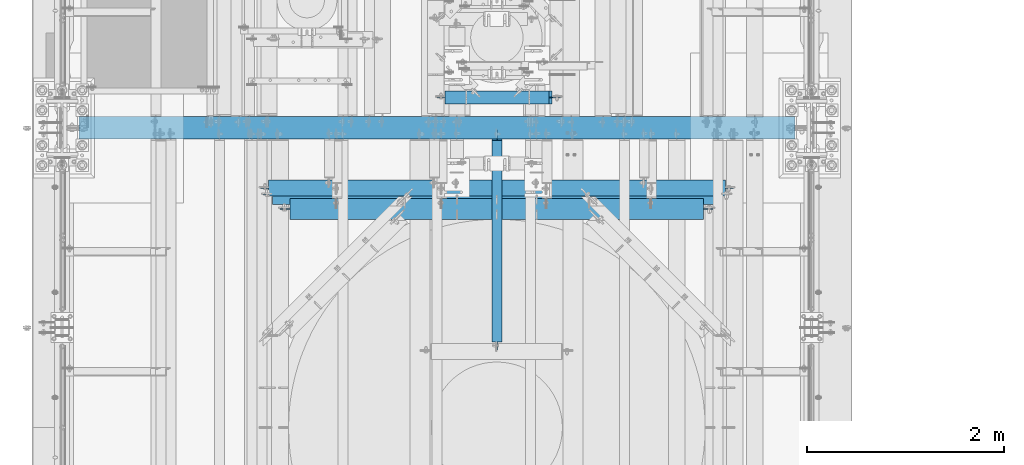
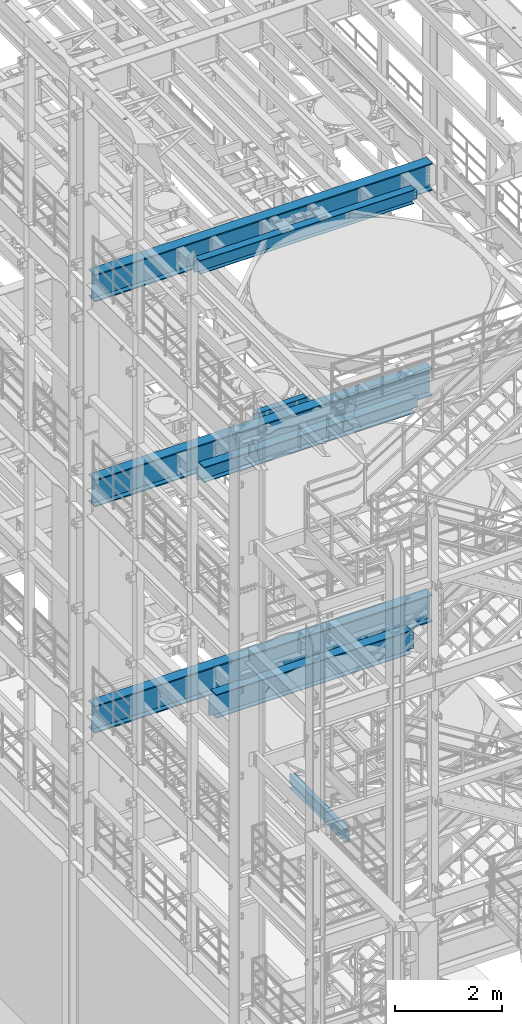
# One storey, part 1014 of 1876: 8 beams, 8 elements without a shape of their own.
"""IFC2X3 building model written with IfcOpenShell, lengths in millimetres."""

from ifc_helpers import new_model, si_unit, frame, origin_with_axes, place, context, subcontext, project, spatial, faceted_brep, material, type_object, element, aggregate, save


model = new_model("IFC2X3")

# Units and contexts
model_context = context("Model", 3, precision=1e-05, world=origin_with_axes())
body_context = subcontext(model_context, "Body", "Model", "MODEL_VIEW")
ifc_project = project(units=[si_unit("LENGTHUNIT", "METRE", prefix="MILLI"), si_unit("AREAUNIT", "SQUARE_METRE"), si_unit("VOLUMEUNIT", "CUBIC_METRE"), si_unit("MASSUNIT", "GRAM", prefix="KILO"), si_unit("TIMEUNIT", "SECOND"), si_unit("PLANEANGLEUNIT", "RADIAN"), si_unit("SOLIDANGLEUNIT", "STERADIAN"), si_unit("THERMODYNAMICTEMPERATUREUNIT", "DEGREE_CELSIUS"), si_unit("LUMINOUSINTENSITYUNIT", "LUMEN")], contexts=[model_context])

# Site, building, storey
site_placement = place(None, origin_with_axes())
site = spatial("IfcSite", under=ifc_project, at=site_placement, CompositionType="ELEMENT")
building_placement = place(site_placement, origin_with_axes())
building = spatial("IfcBuilding", under=site, at=building_placement, Name="Undefined", CompositionType="ELEMENT")
storey_placement = place(building_placement, origin_with_axes())
storey = spatial("IfcBuildingStorey", under=building, at=storey_placement, Name="Undefined", CompositionType="ELEMENT", Elevation=0.0)

# Assembly, beam
assembly_1_placement = place(storey_placement, origin_with_axes())
assembly_1 = element("IfcElementAssembly", 1, at=assembly_1_placement, inside=storey, Name="BEAM", AssemblyPlace="NOTDEFINED", PredefinedType="RIGID_FRAME")
ifc_material = material(Name="STEEL/A992")
beam_type_1 = type_object("IfcBeamType", Name="W12X16", PredefinedType="NOTDEFINED")
beam_1_placement = place(assembly_1_placement, frame((4422.775, -717.55, 4978.4), z_axis=(0.0, 0.0, 1.0), x_axis=(0.0, 1.0, 0.0)))
beam_1 = element("IfcBeam", 2, at=beam_1_placement, type_object=beam_type_1, material=ifc_material, Name="BEAM", ObjectType="W12X16", context=body_context, shape_type="Brep", body=[
    faceted_brep([(-15.875, -3.17500000000018, -126.999999999999), (-15.875, 3.17500000000018, -126.999999999999), (66.6750000000002, 3.17499999999995, -127.0), (66.6750000000002, -3.17499999999995, -127.0), (71.5350797087794, 3.17499999999995, -127.966729922588), (71.5350797087794, -3.17499999999995, -127.966729922588), (75.6552561769331, 3.17499999999995, -130.719743823067), (75.6552561769331, -3.17499999999995, -130.719743823067), (78.4082700774111, 3.17499999999995, -134.839920291221), (78.4082700774111, -3.17499999999995, -134.839920291221), (79.3749999999991, -3.17499999999995, -139.699999809266), (79.3749999999991, 3.17499999999995, -139.699999809266), (79.3749999999991, 3.17499999999995, -146.05), (79.3749999999991, 50.8, -146.05), (79.3749999999991, 50.8, -152.4), (79.3749999999991, -50.8, -152.4), (79.3749999999991, -50.8, -146.05), (79.3749999999991, -3.17499999999995, -146.05), (2113.75625, 50.8000000000002, 146.05), (2113.75625, 3.17500000000018, 146.05), (63.5000000000009, 3.17499999999927, 146.049999999999), (63.4999999247211, 50.8000000000002, 146.049999999999), (50.800000115456, -3.17500000000018, 127.000000000004), (50.800000115456, 3.17500000000018, 127.000000000004), (-15.875, 3.17500000000018, 127.000000000001), (-15.875, -3.17500000000018, 127.000000000001), (55.6600796335015, -3.17500000000018, 127.966729922591), (55.6600796335015, 3.17500000000018, 127.966729922591), (59.7802561016551, -3.17500000000018, 130.719743823069), (59.7802561016551, 3.17500000000018, 130.719743823069), (62.5332700021336, -3.17500000000018, 134.839920291222), (62.5332700021336, 3.17500000000018, 134.839920291222), (63.4999999247211, -3.17500000000018, 139.699999809269), (63.4999999247211, 3.17500000000018, 139.699999809269), (2113.75625, -50.8000000000002, 152.4), (2113.75625, 50.8000000000002, 152.4), (63.4999999247211, 50.8000000000002, 152.400000000001), (63.4999999247211, -50.8000000000002, 152.400000000001), (2113.75625, -50.8000000000002, 146.05), (63.4999999247211, -50.8000000000002, 146.049999999999), (2113.75625, -3.17500000000018, 146.05), (63.5000000000009, -3.17499999999927, 146.049999999999), (2113.75625, -3.17500000000018, 126.999999809264), (2113.75625, 3.17500000000018, 126.999999809264), (2114.72297992259, -3.17500000000018, 122.139920291219), (2114.72297992259, 3.17500000000018, 122.139920291219), (2117.47599382307, -3.17500000000018, 118.019743823065), (2117.47599382307, 3.17500000000018, 118.019743823065), (2121.59617029122, -3.17500000000018, 115.266729922587), (2121.59617029122, 3.17500000000018, 115.266729922587), (2126.45624980927, -3.17500000000018, 114.299999999999), (2126.45624980927, 3.17500000000018, 114.299999999999), (2221.70625, -3.17500000000018, 114.299999999999), (2221.70625, 3.17500000000018, 114.299999999999), (2221.70625, -3.17500000000018, -127.000000000001), (2221.70625, 3.17500000000018, -127.000000000001), (2139.15624980927, -3.17500000000018, -127.000000000001), (2139.15624980927, 3.17500000000018, -127.000000000001), (2134.29617029122, -3.17500000000018, -127.966729922588), (2134.29617029122, 3.17500000000018, -127.966729922588), (2130.17599382307, -3.17500000000018, -130.719743823067), (2130.17599382307, 3.17500000000018, -130.719743823067), (2127.42297992259, -3.17500000000018, -134.839920291221), (2127.42297992259, 3.17500000000018, -134.839920291221), (2126.45625, -3.17500000000018, -139.699999809266), (2126.45625, 3.17500000000018, -139.699999809266), (2126.45625, -3.17500000000018, -146.05), (2126.45625, -50.8000000000002, -146.05), (2126.45625, -50.8000000000002, -152.4), (2126.45625, 50.8000000000002, -152.4), (2126.45625, 50.8000000000002, -146.05), (2126.45625, 3.17500000000018, -146.05)], [[[0, 1, 2, 3]], [[3, 2, 4, 5]], [[5, 4, 6, 7]], [[7, 6, 8, 9]], [[10, 11, 12, 13, 14, 15, 16, 17]], [[9, 8, 11, 10]], [[18, 19, 20, 21]], [[22, 23, 24, 25]], [[26, 27, 23, 22]], [[28, 29, 27, 26]], [[30, 31, 29, 28]], [[32, 33, 31, 30]], [[34, 35, 36, 37]], [[38, 34, 37, 39]], [[40, 38, 39, 41]], [[37, 36, 21, 20, 33, 32, 41, 39]], [[35, 18, 21, 36]], [[34, 38, 40, 42, 43, 19, 18, 35]], [[44, 45, 43, 42]], [[46, 47, 45, 44]], [[48, 49, 47, 46]], [[50, 51, 49, 48]], [[52, 53, 51, 50]], [[53, 52, 54, 55]], [[54, 56, 57, 55]], [[58, 59, 57, 56]], [[60, 61, 59, 58]], [[62, 63, 61, 60]], [[64, 65, 63, 62]], [[66, 67, 68, 69, 70, 71, 65, 64]], [[67, 66, 17, 16]], [[68, 67, 16, 15]], [[69, 68, 15, 14]], [[70, 69, 14, 13]], [[71, 70, 13, 12]], [[6, 4, 2, 1, 24, 23, 27, 29, 31, 33, 20, 19, 43, 45, 47, 49, 51, 53, 55, 57, 59, 61, 63, 65, 71, 12, 11, 8]], [[25, 24, 1, 0]], [[66, 64, 62, 60, 58, 56, 54, 52, 50, 48, 46, 44, 42, 40, 41, 32, 30, 28, 26, 22, 25, 0, 3, 5, 7, 9, 10, 17]]]),
])
aggregate(assembly_1, [beam_1])

assembly_2_placement = place(storey_placement, origin_with_axes())
assembly_2 = element("IfcElementAssembly", 3, at=assembly_2_placement, inside=storey, Name="BEAM", AssemblyPlace="NOTDEFINED", PredefinedType="RIGID_FRAME")
beam_type_2 = type_object("IfcBeamType", Name="W8X18", PredefinedType="NOTDEFINED")
beam_2_placement = place(assembly_2_placement, frame((3892.55, 1831.975, 13206.4125), z_axis=(0.0, 0.0, 1.0), x_axis=(1.0, 0.0, 0.0)))
beam_2 = element("IfcBeam", 4, at=beam_2_placement, type_object=beam_type_2, material=ifc_material, Name="BEAM", ObjectType="W8X18", context=body_context, shape_type="Brep", body=[
    faceted_brep([(1086.64375, -3.17500000000018, -95.25), (1086.64375, -66.6750000000002, -95.25), (1086.64375, -66.6750000000002, -103.1875), (1086.64375, 66.6750000000002, -103.1875), (1086.64375, 66.6750000000002, -95.25), (1086.64375, 3.17500000000018, -95.25), (1086.64375, 3.17500000000018, -90.4874998092673), (1086.64375, -3.17500000000018, -90.4874998092673), (1087.61047992259, 3.17500000000018, -85.6274202912209), (1087.61047992259, -3.17500000000018, -85.6274202912209), (1090.36349382307, 3.17500000000018, -81.5072438230673), (1090.36349382307, -3.17500000000018, -81.5072438230673), (1094.48367029122, 3.17500000000018, -78.7542299225897), (1094.48367029122, -3.17500000000018, -78.7542299225897), (1099.34374980927, 3.17500000000018, -77.7875000000022), (1099.34374980927, -3.17500000000018, -77.7875000000022), (1175.54375, -3.17500000000018, -77.7875000000022), (1175.54375, 3.17500000000018, -77.7875000000022), (4.54747350886464e-13, 3.17500000000018, 95.25), (4.54747350886464e-13, 66.6750000000002, 95.25), (1054.89375, 66.6750000000002, 95.25), (1054.89375, 3.17500000000018, 95.25), (9.52500000000055, -3.17500000000018, -90.4874998092655), (9.52500000000055, 3.17500000000018, -90.4874998092655), (9.52500000000055, 3.17500000000018, -95.25), (9.52500000000055, 66.6750000000002, -95.25), (9.52500000000055, 66.6750000000002, -103.1875), (9.52500000000055, -66.6750000000002, -103.1875), (9.52500000000055, -66.6750000000002, -95.25), (9.52500000000055, -3.17500000000018, -95.25), (8.55827007741254, -3.17500000000018, -85.6274202912191), (8.55827007741254, 3.17500000000018, -85.6274202912191), (5.80525617693456, -3.17500000000018, -81.5072438230654), (5.80525617693456, 3.17500000000018, -81.5072438230654), (1.6850797087809, -3.17500000000018, -78.7542299225879), (1.6850797087809, 3.17500000000018, -78.7542299225879), (-3.17499980926459, -3.17500000000018, -77.7875000000004), (-3.17499980926459, 3.17500000000018, -77.7875000000004), (-79.3750000000005, -3.17500000000018, -77.7875000000004), (-79.3750000000005, 3.17500000000018, -77.7875000000004), (-79.3750000000005, -3.17500000000018, 77.7875000000004), (-79.3750000000005, 3.17500000000018, 77.7875000000004), (-12.6999998092647, -3.17500000000018, 77.7875000000004), (-12.6999998092647, 3.17500000000018, 77.7875000000004), (-7.83992029121919, -3.17500000000018, 78.7542299225879), (-7.83992029121919, 3.17500000000018, 78.7542299225879), (-3.71974382306553, -3.17500000000018, 81.5072438230654), (-3.71974382306553, 3.17500000000018, 81.5072438230654), (-0.966729922587547, -3.17500000000018, 85.6274202912191), (-0.966729922587547, 3.17500000000018, 85.6274202912191), (4.54747350886464e-13, -3.17500000000018, 90.4874998092655), (4.54747350886464e-13, 3.17500000000018, 90.4874998092655), (4.54747350886464e-13, -66.6750000000002, 103.1875), (4.54747350886464e-13, 66.6750000000002, 103.1875), (4.54747350886464e-13, -3.17500000000018, 95.25), (4.54747350886464e-13, -66.6750000000002, 95.25), (1054.89375, -3.17500000000018, 95.25), (1054.89375, -66.6750000000002, 95.25), (1054.89375, -66.6750000000002, 103.1875), (1054.89375, 66.6750000000002, 103.1875), (1054.89375, -3.17500000000018, 90.4874998092637), (1054.89375, 3.17500000000018, 90.4874998092637), (1055.86047992259, -3.17500000000018, 85.6274202912173), (1055.86047992259, 3.17500000000018, 85.6274202912173), (1058.61349382307, -3.17500000000018, 81.5072438230636), (1058.61349382307, 3.17500000000018, 81.5072438230636), (1062.73367029122, -3.17500000000018, 78.7542299225861), (1062.73367029122, 3.17500000000018, 78.7542299225861), (1067.59374980927, -3.17500000000018, 77.7874999999985), (1067.59374980927, 3.17500000000018, 77.7874999999985), (1175.54375, -3.17500000000018, 77.7874999999985), (1175.54375, 3.17500000000018, 77.7874999999985)], [[[0, 1, 2, 3, 4, 5, 6, 7]], [[7, 6, 8, 9]], [[9, 8, 10, 11]], [[11, 10, 12, 13]], [[13, 12, 14, 15]], [[16, 15, 14, 17]], [[18, 19, 20, 21]], [[22, 23, 24, 25, 26, 27, 28, 29]], [[30, 31, 23, 22]], [[32, 33, 31, 30]], [[34, 35, 33, 32]], [[36, 37, 35, 34]], [[38, 39, 37, 36]], [[40, 41, 39, 38]], [[42, 43, 41, 40]], [[44, 45, 43, 42]], [[46, 47, 45, 44]], [[48, 49, 47, 46]], [[50, 51, 49, 48]], [[52, 53, 19, 18, 51, 50, 54, 55]], [[55, 54, 56, 57]], [[52, 55, 57, 58]], [[53, 52, 58, 59]], [[19, 53, 59, 20]], [[58, 57, 56, 60, 61, 21, 20, 59]], [[62, 63, 61, 60]], [[64, 65, 63, 62]], [[66, 67, 65, 64]], [[68, 69, 67, 66]], [[70, 71, 69, 68]], [[71, 70, 16, 17]], [[33, 35, 37, 39, 41, 43, 45, 47, 49, 51, 18, 21, 61, 63, 65, 67, 69, 71, 17, 14, 12, 10, 8, 6, 5, 24, 23, 31]], [[5, 4, 25, 24]], [[4, 3, 26, 25]], [[3, 2, 27, 26]], [[2, 1, 28, 27]], [[1, 0, 29, 28]], [[0, 7, 9, 11, 13, 15, 16, 70, 68, 66, 64, 62, 60, 56, 54, 50, 48, 46, 44, 42, 40, 38, 36, 34, 32, 30, 22, 29]]]),
])
aggregate(assembly_2, [beam_2])

assembly_3_placement = place(storey_placement, origin_with_axes())
assembly_3 = element("IfcElementAssembly", 5, at=assembly_3_placement, inside=storey, Name="BEAM", AssemblyPlace="NOTDEFINED", PredefinedType="RIGID_FRAME")
beam_type_3 = type_object("IfcBeamType", Name="W12X30", PredefinedType="NOTDEFINED")
beam_3_placement = place(assembly_3_placement, frame((1930.40018598705, 911.224999999455, 17826.0375), z_axis=(0.0, 0.0, 1.0), x_axis=(1.0, 0.0, 0.0)))
beam_3 = element("IfcBeam", 6, at=beam_3_placement, type_object=beam_type_3, material=ifc_material, Name="BEAM", ObjectType="W12X30", context=body_context, shape_type="Brep", body=[
    faceted_brep([(4797.4246272902, -3.17499999999995, -146.049999999999), (4797.4246272902, -82.55, -146.049999999999), (4797.4246272902, -82.55, -157.162499999999), (4797.4246272902, 82.55, -157.162499999999), (4797.4246272902, 82.55, -146.049999999999), (4797.4246272902, 3.17499999999995, -146.049999999999), (4797.4246272902, 3.17499999999995, -138.112499809271), (4797.4246272902, -3.17499999999995, -138.112499809271), (4798.39135721279, 3.17499999999995, -133.252420291225), (4798.39135721279, -3.17499999999995, -133.252420291225), (4801.14437111326, 3.17499999999995, -129.132243823071), (4801.14437111326, -3.17499999999995, -129.132243823071), (4805.26454758142, 3.17499999999995, -126.379229922593), (4805.26454758142, -3.17499999999995, -126.379229922593), (4810.12462709946, 3.17499999999995, -125.412500000006), (4810.12462709946, -3.17499999999995, -125.412500000006), (4892.6746272902, -3.17499999999995, -125.412500000006), (4892.6746272902, 3.17499999999995, -125.412500000006), (165.099700464235, 3.17499999999995, 146.049999999999), (165.099700464235, 82.55, 146.049999999999), (4813.2996272902, 82.55, 146.049999999999), (4813.2996272902, 3.17499999999995, 146.049999999999), (180.974700464235, -3.17500000000007, -138.112499809271), (180.974700464235, 3.17499999999995, -138.112499809271), (180.974700464235, 3.17499999999995, -146.049999999999), (180.974700464235, 82.55, -146.049999999999), (180.974700464235, 82.55, -157.162499999999), (180.974700464235, -82.55, -157.162499999999), (180.974700464235, -82.55, -146.049999999999), (180.974700464235, -3.17499999999995, -146.049999999999), (180.007970541647, -3.17500000000007, -133.252420291225), (180.007970541647, 3.17499999999995, -133.252420291225), (177.254956641169, -3.17500000000007, -129.132243823071), (177.254956641169, 3.17499999999995, -129.132243823071), (173.134780173015, -3.17500000000007, -126.379229922593), (173.134780173015, 3.17499999999995, -126.379229922593), (168.27470065497, -3.17500000000007, -125.412500000006), (168.27470065497, 3.17499999999995, -125.412500000006), (85.7247004642345, -3.17499999999995, -125.412500000006), (85.7247004642345, 3.17499999999995, -125.412500000006), (85.7247004642345, -3.17499999999995, 131.762499999997), (85.7247004642345, 3.17499999999995, 131.762499999997), (152.39970065497, -3.17499999999995, 131.762499999997), (152.39970065497, 3.17499999999995, 131.762499999997), (157.259780173015, -3.17499999999995, 132.729229922585), (157.259780173015, 3.17499999999995, 132.729229922585), (161.379956641169, -3.17499999999995, 135.482243823062), (161.379956641169, 3.17499999999995, 135.482243823062), (164.132970541647, -3.17499999999995, 139.602420291216), (164.132970541647, 3.17499999999995, 139.602420291216), (165.099700464235, -3.17499999999995, 144.462499809262), (165.099700464235, 3.17499999999995, 144.462499809262), (165.099700464235, -82.55, 157.162499999999), (165.099700464235, 82.55, 157.162499999999), (165.099700464235, -3.17499999999995, 146.049999999999), (165.099700464235, -82.55, 146.049999999999), (4813.2996272902, -3.17499999999995, 146.049999999999), (4813.2996272902, -82.55, 146.049999999999), (4813.2996272902, -82.55, 157.162499999999), (4813.2996272902, 82.55, 157.162499999999), (4813.2996272902, -3.17499999999995, 144.462499809262), (4813.2996272902, 3.17500000000007, 144.462499809262), (4814.26635721279, -3.17499999999995, 139.602420291216), (4814.26635721279, 3.17500000000007, 139.602420291216), (4817.01937111326, -3.17499999999995, 135.482243823062), (4817.01937111326, 3.17500000000007, 135.482243823062), (4821.13954758142, -3.17499999999995, 132.729229922585), (4821.13954758142, 3.17500000000007, 132.729229922585), (4825.99962709946, -3.17499999999995, 131.762499999997), (4825.99962709946, 3.17500000000007, 131.762499999997), (4892.6746272902, -3.17499999999995, 131.762499999997), (4892.6746272902, 3.17499999999995, 131.762499999997)], [[[0, 1, 2, 3, 4, 5, 6, 7]], [[7, 6, 8, 9]], [[9, 8, 10, 11]], [[11, 10, 12, 13]], [[13, 12, 14, 15]], [[16, 15, 14, 17]], [[18, 19, 20, 21]], [[22, 23, 24, 25, 26, 27, 28, 29]], [[30, 31, 23, 22]], [[32, 33, 31, 30]], [[34, 35, 33, 32]], [[36, 37, 35, 34]], [[38, 39, 37, 36]], [[40, 41, 39, 38]], [[42, 43, 41, 40]], [[44, 45, 43, 42]], [[46, 47, 45, 44]], [[48, 49, 47, 46]], [[50, 51, 49, 48]], [[52, 53, 19, 18, 51, 50, 54, 55]], [[55, 54, 56, 57]], [[52, 55, 57, 58]], [[53, 52, 58, 59]], [[19, 53, 59, 20]], [[58, 57, 56, 60, 61, 21, 20, 59]], [[62, 63, 61, 60]], [[64, 65, 63, 62]], [[66, 67, 65, 64]], [[68, 69, 67, 66]], [[70, 71, 69, 68]], [[71, 70, 16, 17]], [[12, 10, 8, 6, 5, 24, 23, 31, 33, 35, 37, 39, 41, 43, 45, 47, 49, 51, 18, 21, 61, 63, 65, 67, 69, 71, 17, 14]], [[25, 24, 5, 4]], [[26, 25, 4, 3]], [[27, 26, 3, 2]], [[28, 27, 2, 1]], [[29, 28, 1, 0]], [[70, 68, 66, 64, 62, 60, 56, 54, 50, 48, 46, 44, 42, 40, 38, 36, 34, 32, 30, 22, 29, 0, 7, 9, 11, 13, 15, 16]]]),
])
aggregate(assembly_3, [beam_3])

assembly_4_placement = place(storey_placement, origin_with_axes())
assembly_4 = element("IfcElementAssembly", 7, at=assembly_4_placement, inside=storey, Name="BEAM", AssemblyPlace="NOTDEFINED", PredefinedType="RIGID_FRAME")
beam_type_4 = type_object("IfcBeamType", Name="W14X48", PredefinedType="NOTDEFINED")
beam_4_placement = place(assembly_4_placement, frame((1930.4, 844.55, 13134.975), z_axis=(0.0, 0.0, 1.0), x_axis=(1.0, 0.0, 0.0)))
beam_4 = element("IfcBeam", 8, at=beam_4_placement, type_object=beam_type_4, material=ifc_material, Name="BEAM", ObjectType="W14X48", context=body_context, shape_type="Brep", body=[
    faceted_brep([(4764.88125, -3.96875, -158.75), (4764.88125, -101.6, -158.75), (4764.88125, -101.6, -174.625), (4764.88125, 101.6, -174.625), (4764.88125, 101.6, -158.75), (4764.88125, 3.96875, -158.75), (4764.88125, 3.96875, -155.574999809265), (4764.88125, -3.96875, -155.574999809265), (4765.84797992259, 3.96875, -150.714920291219), (4765.84797992259, -3.96875, -150.714920291219), (4768.60099382306, 3.96875, -146.594743823065), (4768.60099382306, -3.96875, -146.594743823065), (4772.72117029122, 3.96875, -143.841729922588), (4772.72117029122, -3.96875, -143.841729922588), (4777.58124980926, 3.96875, -142.875), (4777.58124980926, -3.96875, -142.875), (4866.48125, -3.96875, -142.875), (4866.48125, 3.96875, -142.875), (210.344030879795, 3.96875, 158.75), (210.344030879795, 101.6, 158.75), (4768.05625, 101.6, 158.75), (4768.05625, 3.96875, 158.75), (213.519030879793, -3.96875, -155.574999809265), (213.519030879793, 3.96875, -155.574999809265), (213.519030879794, 3.96875, -158.75), (213.519030879794, 101.6, -158.75), (213.519030879794, 101.6, -174.625), (213.519030879794, -101.6, -174.625), (213.519030879794, -101.6, -158.75), (213.519030879794, -3.96875, -158.75), (212.552300957205, -3.96875, -150.714920291219), (212.552300957205, 3.96875, -150.714920291219), (209.799287056728, -3.96875, -146.594743823065), (209.799287056728, 3.96875, -146.594743823065), (205.679110588574, -3.96875, -143.841729922588), (205.679110588574, 3.96875, -143.841729922588), (200.819031070528, -3.96875, -142.875), (200.819031070528, 3.96875, -142.875), (111.919030879794, -3.96875, -142.875), (111.919030879794, 3.96875, -142.875), (111.919030879794, -3.96875, 142.875), (111.919030879794, 3.96875, 142.875), (197.644031070529, -3.96875, 142.875), (197.644031070529, 3.96875, 142.875), (202.504110588574, -3.96875, 143.841729922588), (202.504110588574, 3.96875, 143.841729922588), (206.624287056728, -3.96875, 146.594743823065), (206.624287056728, 3.96875, 146.594743823065), (209.377300957206, -3.96875, 150.714920291219), (209.377300957206, 3.96875, 150.714920291219), (210.344030879794, -3.96875, 155.574999809265), (210.344030879794, 3.96875, 155.574999809265), (210.344030879795, -101.6, 174.625), (210.344030879795, 101.6, 174.625), (210.344030879795, -3.96875, 158.75), (210.344030879795, -101.6, 158.75), (4768.05625, -3.96875, 158.75), (4768.05625, -101.6, 158.75), (4768.05625, -101.6, 174.625), (4768.05625, 101.6, 174.625), (4768.05625, -3.96875, 155.574999809265), (4768.05625, 3.96875, 155.574999809265), (4769.02297992259, -3.96875, 150.714920291219), (4769.02297992259, 3.96875, 150.714920291219), (4771.77599382306, -3.96875, 146.594743823065), (4771.77599382306, 3.96875, 146.594743823065), (4775.89617029122, -3.96875, 143.841729922588), (4775.89617029122, 3.96875, 143.841729922588), (4780.75624980926, -3.96875, 142.875), (4780.75624980926, 3.96875, 142.875), (4866.48125, -3.96875, 142.875), (4866.48125, 3.96875, 142.875)], [[[0, 1, 2, 3, 4, 5, 6, 7]], [[7, 6, 8, 9]], [[9, 8, 10, 11]], [[11, 10, 12, 13]], [[13, 12, 14, 15]], [[16, 15, 14, 17]], [[18, 19, 20, 21]], [[22, 23, 24, 25, 26, 27, 28, 29]], [[30, 31, 23, 22]], [[32, 33, 31, 30]], [[34, 35, 33, 32]], [[36, 37, 35, 34]], [[38, 39, 37, 36]], [[40, 41, 39, 38]], [[42, 43, 41, 40]], [[44, 45, 43, 42]], [[46, 47, 45, 44]], [[48, 49, 47, 46]], [[50, 51, 49, 48]], [[52, 53, 19, 18, 51, 50, 54, 55]], [[55, 54, 56, 57]], [[52, 55, 57, 58]], [[53, 52, 58, 59]], [[19, 53, 59, 20]], [[58, 57, 56, 60, 61, 21, 20, 59]], [[62, 63, 61, 60]], [[64, 65, 63, 62]], [[66, 67, 65, 64]], [[68, 69, 67, 66]], [[70, 71, 69, 68]], [[71, 70, 16, 17]], [[12, 10, 8, 6, 5, 24, 23, 31, 33, 35, 37, 39, 41, 43, 45, 47, 49, 51, 18, 21, 61, 63, 65, 67, 69, 71, 17, 14]], [[25, 24, 5, 4]], [[26, 25, 4, 3]], [[27, 26, 3, 2]], [[28, 27, 2, 1]], [[29, 28, 1, 0]], [[70, 68, 66, 64, 62, 60, 56, 54, 50, 48, 46, 44, 42, 40, 38, 36, 34, 32, 30, 22, 29, 0, 7, 9, 11, 13, 15, 16]]]),
])
aggregate(assembly_4, [beam_4])

assembly_5_placement = place(storey_placement, origin_with_axes())
assembly_5 = element("IfcElementAssembly", 9, at=assembly_5_placement, inside=storey, Name="BEAM", AssemblyPlace="NOTDEFINED", PredefinedType="RIGID_FRAME")
beam_type_5 = type_object("IfcBeamType", Name="W21X68", PredefinedType="NOTDEFINED")
beam_5_placement = place(assembly_5_placement, frame((2197.1, 698.698438, 7885.1125), z_axis=(0.0, 0.0, 1.0), x_axis=(1.0, 0.0, 0.0)))
beam_5 = element("IfcBeam", 10, at=beam_5_placement, type_object=beam_type_5, material=ifc_material, Name="BEAM", ObjectType="W21X68", context=body_context, shape_type="Brep", body=[
    faceted_brep([(18.2562500000008, -5.55625000000009, -236.537499999999), (18.2562500000008, 5.55625000000009, -236.537499999999), (107.156250190736, 5.55625000000009, -236.537499999999), (107.156250190736, -5.55625000000009, -236.537499999999), (112.016329708781, 5.55625000000009, -237.504229922586), (112.016329708781, -5.55625000000009, -237.504229922586), (116.136506176935, 5.55625000000009, -240.257243823065), (116.136506176935, -5.55625000000009, -240.257243823065), (118.889520077413, 5.55625000000009, -244.377420291218), (118.889520077413, -5.55625000000009, -244.377420291218), (119.856250000001, -5.55625000000009, -249.237499809264), (119.856250000001, 5.55625000000009, -249.237499809264), (119.856250000001, 5.55625000000009, -250.825), (119.856250000001, 104.775, -250.825), (119.856250000001, 104.775, -268.2875), (119.856250000001, -104.775, -268.2875), (119.856250000001, -104.775, -250.825), (119.856250000001, -5.55625000000009, -250.825), (119.856250000001, 5.55625000000009, 250.825), (119.856250000001, 104.775, 250.825), (4325.14374997612, 104.775, 250.825), (4325.14374997612, 5.55625000000009, 250.825), (107.156250190736, -5.55625000000009, 236.537500000001), (107.156250190736, 5.55625000000009, 236.537500000001), (18.2562500000008, 5.55625000000009, 236.537500000001), (18.2562500000008, -5.55625000000009, 236.537500000001), (112.016329708781, -5.55625000000009, 237.504229922589), (112.016329708781, 5.55625000000009, 237.504229922589), (116.136506176935, -5.55625000000009, 240.257243823067), (116.136506176935, 5.55625000000009, 240.257243823067), (118.889520077413, -5.55625000000009, 244.377420291221), (118.889520077413, 5.55625000000009, 244.377420291221), (119.856250000001, -5.55625000000009, 249.237499809266), (119.856250000001, 5.55625000000009, 249.237499809266), (119.856250000001, 104.775, 268.2875), (119.856250000001, -104.775, 268.2875), (4325.14374997612, -104.775, 268.2875), (4325.14374997612, 104.775, 268.2875), (119.856250000001, -104.775, 250.825), (4325.14374997612, -104.775, 250.825), (119.856250000001, -5.55625000000009, 250.825), (4325.14374997612, -5.55625000000009, 250.825), (4325.14374997612, -5.55625000000009, 249.237499809266), (4325.14374997612, 5.55625000000009, 249.237499809266), (4326.11047989871, -5.55625000000009, 244.377420291221), (4326.11047989871, 5.55625000000009, 244.377420291221), (4328.86349379918, -5.55625000000009, 240.257243823067), (4328.86349379918, 5.55625000000009, 240.257243823067), (4332.98367026734, -5.55625000000009, 237.504229922589), (4332.98367026734, 5.55625000000009, 237.504229922589), (4337.84374978538, -5.55625000000009, 236.537500000001), (4337.84374978538, 5.55625000000009, 236.537500000001), (4426.74374997612, -5.55625000000009, 236.537500000001), (4426.74374997612, 5.55625000000009, 236.537500000001), (4426.74374997612, -5.55625000000009, -236.537499999999), (4426.74374997612, 5.55625000000009, -236.537499999999), (4337.84374978538, -5.55625000000009, -236.537499999999), (4337.84374978538, 5.55625000000009, -236.537499999999), (4332.98367026734, -5.55625000000009, -237.504229922586), (4332.98367026734, 5.55625000000009, -237.504229922586), (4328.86349379918, -5.55625000000009, -240.257243823065), (4328.86349379918, 5.55625000000009, -240.257243823065), (4326.11047989871, -5.55625000000009, -244.377420291218), (4326.11047989871, 5.55625000000009, -244.377420291218), (4325.14374997612, -5.55625000000009, -249.237499809264), (4325.14374997612, 5.55625000000009, -249.237499809264), (4325.14374997612, -5.55625000000009, -250.825), (4325.14374997612, -104.775, -250.825), (4325.14374997612, -104.775, -268.2875), (4325.14374997612, 104.775, -268.2875), (4325.14374997612, 104.775, -250.825), (4325.14374997612, 5.55625000000009, -250.825)], [[[0, 1, 2, 3]], [[3, 2, 4, 5]], [[5, 4, 6, 7]], [[7, 6, 8, 9]], [[10, 11, 12, 13, 14, 15, 16, 17]], [[9, 8, 11, 10]], [[18, 19, 20, 21]], [[22, 23, 24, 25]], [[26, 27, 23, 22]], [[28, 29, 27, 26]], [[30, 31, 29, 28]], [[32, 33, 31, 30]], [[34, 35, 36, 37]], [[35, 38, 39, 36]], [[38, 40, 41, 39]], [[35, 34, 19, 18, 33, 32, 40, 38]], [[19, 34, 37, 20]], [[36, 39, 41, 42, 43, 21, 20, 37]], [[44, 45, 43, 42]], [[46, 47, 45, 44]], [[48, 49, 47, 46]], [[50, 51, 49, 48]], [[52, 53, 51, 50]], [[53, 52, 54, 55]], [[54, 56, 57, 55]], [[58, 59, 57, 56]], [[60, 61, 59, 58]], [[62, 63, 61, 60]], [[64, 65, 63, 62]], [[66, 67, 68, 69, 70, 71, 65, 64]], [[17, 16, 67, 66]], [[16, 15, 68, 67]], [[15, 14, 69, 68]], [[14, 13, 70, 69]], [[13, 12, 71, 70]], [[59, 61, 63, 65, 71, 12, 11, 8, 6, 4, 2, 1, 24, 23, 27, 29, 31, 33, 18, 21, 43, 45, 47, 49, 51, 53, 55, 57]], [[25, 24, 1, 0]], [[52, 50, 48, 46, 44, 42, 41, 40, 32, 30, 28, 26, 22, 25, 0, 3, 5, 7, 9, 10, 17, 66, 64, 62, 60, 58, 56, 54]]]),
])
aggregate(assembly_5, [beam_5])

assembly_6_placement = place(storey_placement, origin_with_axes())
assembly_6 = element("IfcElementAssembly", 11, at=assembly_6_placement, inside=storey, Name="BEAM", AssemblyPlace="NOTDEFINED", PredefinedType="RIGID_FRAME")
beam_type_6 = type_object("IfcBeamType", Name="W24X103", PredefinedType="NOTDEFINED")
beam_6_placement = place(assembly_6_placement, frame((0.0, 1524.0, 17672.05), z_axis=(0.0, 0.0, 1.0), x_axis=(1.0, 0.0, 0.0)))
beam_6 = element("IfcBeam", 12, at=beam_6_placement, type_object=beam_type_6, material=ifc_material, Name="BEAM", ObjectType="W24X103", context=body_context, shape_type="Brep", body=[
    faceted_brep([(171.45, 114.3, -311.150000000001), (171.45, 114.3, -285.75), (7448.55, 114.3, -285.75), (7448.55, 114.3, -311.150000000001), (171.45, 7.14374999999995, -285.75), (7448.55, 7.14374999999995, -285.75), (171.45, 7.14374999999995, 285.75), (7448.55, 7.14374999999995, 285.75), (171.45, 114.3, 285.75), (7448.55, 114.3, 285.75), (171.45, 114.3, 311.150000000001), (7448.55, 114.3, 311.150000000001), (171.45, -114.3, 311.150000000001), (7448.55, -114.3, 311.150000000001), (171.45, -114.3, 285.75), (7448.55, -114.3, 285.75), (171.45, -7.14374999999995, 285.75), (7448.55, -7.14374999999995, 285.75), (171.45, -7.14374999999995, -285.75), (7448.55, -7.14374999999995, -285.75), (171.45, -114.3, -285.75), (7448.55, -114.3, -285.75), (171.45, -114.3, -311.150000000001), (7448.55, -114.3, -311.150000000001)], [[[0, 1, 2, 3]], [[1, 4, 5, 2]], [[4, 6, 7, 5]], [[6, 8, 9, 7]], [[8, 10, 11, 9]], [[10, 12, 13, 11]], [[12, 14, 15, 13]], [[14, 16, 17, 15]], [[16, 18, 19, 17]], [[18, 20, 21, 19]], [[20, 22, 23, 21]], [[22, 0, 3, 23]], [[5, 7, 9, 11, 13, 15, 17, 19, 21, 23, 3, 2]], [[22, 20, 18, 16, 14, 12, 10, 8, 6, 4, 1, 0]]]),
])
aggregate(assembly_6, [beam_6])

assembly_7_placement = place(storey_placement, origin_with_axes())
assembly_7 = element("IfcElementAssembly", 13, at=assembly_7_placement, inside=storey, Name="BEAM", AssemblyPlace="NOTDEFINED", PredefinedType="RIGID_FRAME")
beam_7_placement = place(assembly_7_placement, frame((0.0, 1524.0, 12998.45), z_axis=(0.0, 0.0, 1.0), x_axis=(1.0, 0.0, 0.0)))
beam_7 = element("IfcBeam", 14, at=beam_7_placement, type_object=beam_type_6, material=ifc_material, Name="BEAM", ObjectType="W24X103", context=body_context, shape_type="Brep", body=[
    faceted_brep([(171.45, 114.3, -311.150000000001), (171.45, 114.3, -285.75), (7448.55, 114.3, -285.75), (7448.55, 114.3, -311.150000000001), (171.45, 7.14374999999995, -285.75), (7448.55, 7.14374999999995, -285.75), (171.45, 7.14374999999995, 285.75), (7448.55, 7.14374999999995, 285.75), (171.45, 114.3, 285.75), (7448.55, 114.3, 285.75), (171.45, 114.3, 311.150000000001), (7448.55, 114.3, 311.150000000001), (171.45, -114.3, 311.150000000001), (7448.55, -114.3, 311.150000000001), (171.45, -114.3, 285.75), (7448.55, -114.3, 285.75), (171.45, -7.14374999999995, 285.75), (7448.55, -7.14374999999995, 285.75), (171.45, -7.14374999999995, -285.75), (7448.55, -7.14374999999995, -285.75), (171.45, -114.3, -285.75), (7448.55, -114.3, -285.75), (171.45, -114.3, -311.150000000001), (7448.55, -114.3, -311.150000000001)], [[[0, 1, 2, 3]], [[1, 4, 5, 2]], [[4, 6, 7, 5]], [[6, 8, 9, 7]], [[8, 10, 11, 9]], [[10, 12, 13, 11]], [[12, 14, 15, 13]], [[14, 16, 17, 15]], [[16, 18, 19, 17]], [[18, 20, 21, 19]], [[20, 22, 23, 21]], [[22, 0, 3, 23]], [[5, 7, 9, 11, 13, 15, 17, 19, 21, 23, 3, 2]], [[22, 20, 18, 16, 14, 12, 10, 8, 6, 4, 1, 0]]]),
])
aggregate(assembly_7, [beam_7])

assembly_8_placement = place(storey_placement, origin_with_axes())
assembly_8 = element("IfcElementAssembly", 15, at=assembly_8_placement, inside=storey, Name="BEAM", AssemblyPlace="NOTDEFINED", PredefinedType="RIGID_FRAME")
beam_8_placement = place(assembly_8_placement, frame((0.0, 1524.0, 7842.25), z_axis=(0.0, 0.0, 1.0), x_axis=(1.0, 0.0, 0.0)))
beam_8 = element("IfcBeam", 16, at=beam_8_placement, type_object=beam_type_6, material=ifc_material, Name="BEAM", ObjectType="W24X103", context=body_context, shape_type="Brep", body=[
    faceted_brep([(171.45, 114.3, -311.150000000001), (171.45, 114.3, -285.75), (7448.55, 114.3, -285.75), (7448.55, 114.3, -311.150000000001), (171.45, 7.14374999999995, -285.75), (7448.55, 7.14374999999995, -285.75), (171.45, 7.14374999999995, 285.75), (7448.55, 7.14374999999995, 285.75), (171.45, 114.3, 285.75), (7448.55, 114.3, 285.75), (171.45, 114.3, 311.150000000001), (7448.55, 114.3, 311.150000000001), (171.45, -114.3, 311.150000000001), (7448.55, -114.3, 311.150000000001), (171.45, -114.3, 285.75), (7448.55, -114.3, 285.75), (171.45, -7.14374999999995, 285.75), (7448.55, -7.14374999999995, 285.75), (171.45, -7.14374999999995, -285.75), (7448.55, -7.14374999999995, -285.75), (171.45, -114.3, -285.75), (7448.55, -114.3, -285.75), (171.45, -114.3, -311.150000000001), (7448.55, -114.3, -311.150000000001)], [[[0, 1, 2, 3]], [[1, 4, 5, 2]], [[4, 6, 7, 5]], [[6, 8, 9, 7]], [[8, 10, 11, 9]], [[10, 12, 13, 11]], [[12, 14, 15, 13]], [[14, 16, 17, 15]], [[16, 18, 19, 17]], [[18, 20, 21, 19]], [[20, 22, 23, 21]], [[22, 0, 3, 23]], [[5, 7, 9, 11, 13, 15, 17, 19, 21, 23, 3, 2]], [[22, 20, 18, 16, 14, 12, 10, 8, 6, 4, 1, 0]]]),
])
aggregate(assembly_8, [beam_8])

save(model, "model.ifc")
